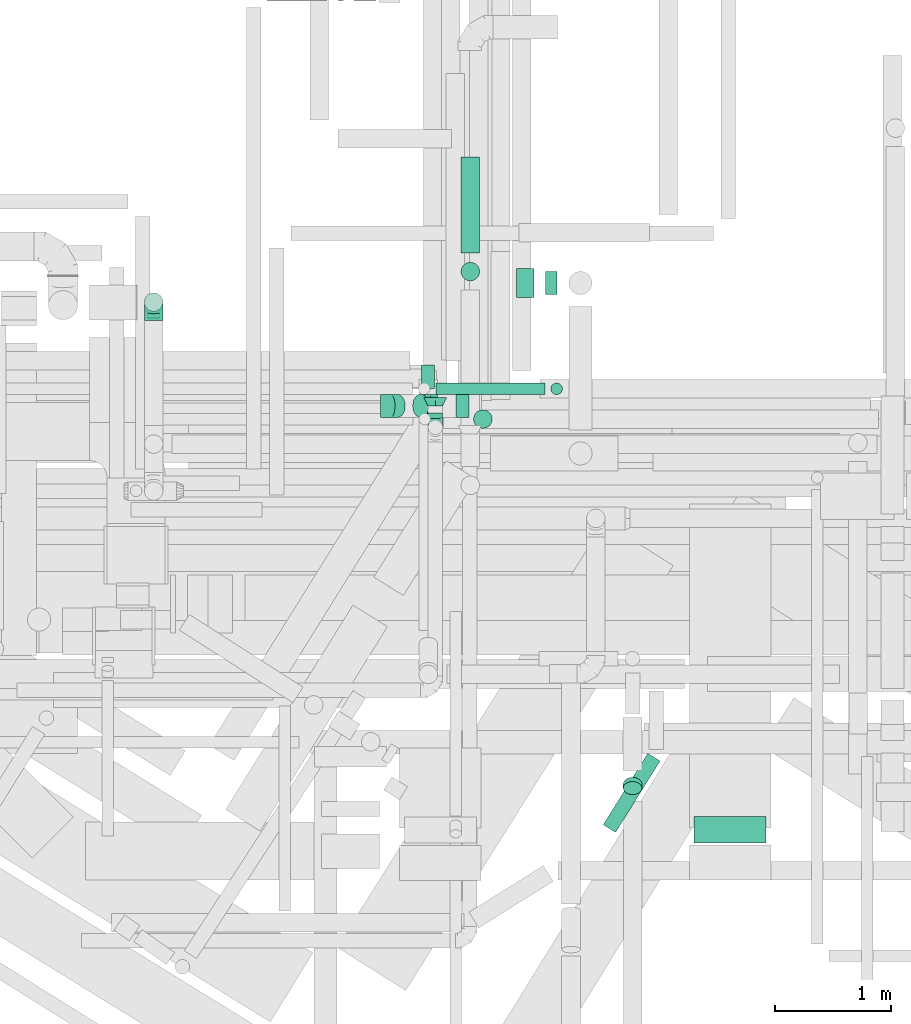
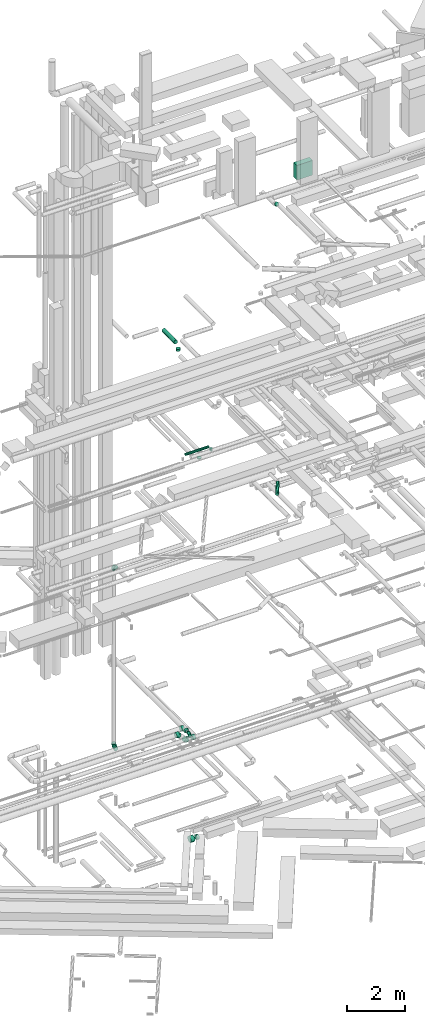
# One storey, part 101 of 337: 10 flow segments, 8 flow fittings.
"""IFC2X3 building model written with IfcOpenShell, lengths in millimetres."""

from ifc_helpers import new_model, entity, si_unit, converted_unit, derived_unit, direction, frame, origin, origin_2d_with_axis, place, context, subcontext, project, spatial, rectangle, circle, extrude, faceted_brep, source, transform, mapped, material, type_object, type_shapes, element, save


model = new_model("IFC2X3")

# Units and contexts
model_context = context("Model", 3, precision=0.01, world=origin(), true_north=direction((6.12303176911189e-17, 1.0)))
body_context = subcontext(model_context, "Body", "Model", "MODEL_VIEW")
ifc_project = project(units=[si_unit("LENGTHUNIT", "METRE", prefix="MILLI"), si_unit("AREAUNIT", "SQUARE_METRE"), si_unit("VOLUMEUNIT", "CUBIC_METRE"), converted_unit("PLANEANGLEUNIT", "DEGREE", entity("IfcRatioMeasure", 0.0174532925199433), si_unit("PLANEANGLEUNIT", "RADIAN"), dimensions=[0, 0, 0, 0, 0, 0, 0]), si_unit("MASSUNIT", "GRAM", prefix="KILO"), derived_unit("MASSDENSITYUNIT", [(si_unit("MASSUNIT", "GRAM", prefix="KILO"), 1), (si_unit("LENGTHUNIT", "METRE"), -3)]), derived_unit("MOMENTOFINERTIAUNIT", [(si_unit("LENGTHUNIT", "METRE"), 4)]), si_unit("TIMEUNIT", "SECOND"), si_unit("FREQUENCYUNIT", "HERTZ"), si_unit("THERMODYNAMICTEMPERATUREUNIT", "DEGREE_CELSIUS"), derived_unit("THERMALTRANSMITTANCEUNIT", [(si_unit("MASSUNIT", "GRAM", prefix="KILO"), 1), (si_unit("THERMODYNAMICTEMPERATUREUNIT", "KELVIN"), -1), (si_unit("TIMEUNIT", "SECOND"), -3)]), derived_unit("VOLUMETRICFLOWRATEUNIT", [(si_unit("LENGTHUNIT", "METRE"), 3), (si_unit("TIMEUNIT", "SECOND"), -1)]), derived_unit("MASSFLOWRATEUNIT", [(si_unit("MASSUNIT", "GRAM", prefix="KILO"), 1), (si_unit("TIMEUNIT", "SECOND"), -1)]), derived_unit("ROTATIONALFREQUENCYUNIT", [(si_unit("TIMEUNIT", "SECOND"), -1)]), si_unit("ELECTRICCURRENTUNIT", "AMPERE"), si_unit("ELECTRICVOLTAGEUNIT", "VOLT"), si_unit("POWERUNIT", "WATT"), si_unit("FORCEUNIT", "NEWTON", prefix="KILO"), si_unit("ILLUMINANCEUNIT", "LUX"), si_unit("LUMINOUSFLUXUNIT", "LUMEN"), si_unit("LUMINOUSINTENSITYUNIT", "CANDELA"), derived_unit("USERDEFINED", [(si_unit("MASSUNIT", "GRAM", prefix="KILO"), -1), (si_unit("LENGTHUNIT", "METRE"), -2), (si_unit("TIMEUNIT", "SECOND"), 3), (si_unit("LUMINOUSFLUXUNIT", "LUMEN"), 1)]), derived_unit("LINEARVELOCITYUNIT", [(si_unit("LENGTHUNIT", "METRE"), 1), (si_unit("TIMEUNIT", "SECOND"), -1)]), si_unit("PRESSUREUNIT", "PASCAL"), derived_unit("USERDEFINED", [(si_unit("LENGTHUNIT", "METRE"), -2), (si_unit("MASSUNIT", "GRAM", prefix="KILO"), 1), (si_unit("TIMEUNIT", "SECOND"), -2)]), derived_unit("LINEARFORCEUNIT", [(si_unit("MASSUNIT", "GRAM", prefix="KILO"), 1), (si_unit("LENGTHUNIT", "METRE"), 1), (si_unit("TIMEUNIT", "SECOND"), -2), (si_unit("LENGTHUNIT", "METRE"), -1)]), derived_unit("PLANARFORCEUNIT", [(si_unit("MASSUNIT", "GRAM", prefix="KILO"), 1), (si_unit("LENGTHUNIT", "METRE"), 1), (si_unit("TIMEUNIT", "SECOND"), -2), (si_unit("LENGTHUNIT", "METRE"), -2)])], contexts=[model_context])

# Site, building, storey
site_placement = place(None, origin())
site = spatial("IfcSite", under=ifc_project, at=site_placement, CompositionType="ELEMENT")
building_placement = place(site_placement, origin())
building = spatial("IfcBuilding", under=site, at=building_placement, CompositionType="ELEMENT")
storey_placement = place(building_placement, origin())
storey = spatial("IfcBuildingStorey", under=building, at=storey_placement, CompositionType="ELEMENT", Elevation=0.0)

# Flow segments
duct_segment_type_1 = type_object("IfcDuctSegmentType", PredefinedType="NOTDEFINED")
flow_segment_1_placement = place(storey_placement, frame((15177.92, 9281.6, 28512.0)))
element("IfcFlowSegment", 1, at=flow_segment_1_placement, inside=storey, type_object=duct_segment_type_1, context=body_context, shape_type="SweptSolid", body=[
    extrude(rectangle(XDim=228.096941669532, YDim=620.0, at=origin_2d_with_axis()), frame((310.0, 114.05, 0.0), z_axis=(0.0, 0.0, 1.0), x_axis=(0.0, -1.0, 0.0)), (0.0, 0.0, 1.0), 619.999999999998),
])
duct_segment_type_2 = type_object("IfcDuctSegmentType", PredefinedType="NOTDEFINED")
flow_segment_2_placement = place(storey_placement, frame((13648.94, 13974.38, -1929.6)))
element("IfcFlowSegment", 2, at=flow_segment_2_placement, inside=storey, type_object=duct_segment_type_2, context=body_context, shape_type="SweptSolid", body=[
    extrude(circle(Radius=125.0, at=origin_2d_with_axis()), frame((0.0, 126.6, 126.6), z_axis=(1.0, 0.0, 0.0), x_axis=(0.0, 1.0, 0.0)), (0.0, 0.0, 1.0), 151.417781054954),
])
flow_segment_3_placement = place(storey_placement, frame((13900.36, 13999.38, -1904.6)))
element("IfcFlowSegment", 3, at=flow_segment_3_placement, inside=storey, type_object=duct_segment_type_2, context=body_context, shape_type="SweptSolid", body=[
    extrude(circle(Radius=100.0, at=origin_2d_with_axis()), frame((0.0, 101.6, 101.6), z_axis=(1.0, 0.0, 0.0), x_axis=(0.0, 1.0, 0.0)), (0.0, 0.0, 1.0), 98.636704749991),
])
flow_segment_4_placement = place(storey_placement, frame((14394.03, 9370.13, 15323.4)))
element("IfcFlowSegment", 4, at=flow_segment_4_placement, inside=storey, type_object=duct_segment_type_2, context=body_context, shape_type="SweptSolid", body=[
    extrude(circle(Radius=62.5, at=origin_2d_with_axis()), frame((54.64, 34.65, 64.1), z_axis=(0.528869419396582, 0.848703209153307, 0.0), x_axis=(-0.848703209153307, 0.528869419396582, 0.0)), (0.0, 0.0, 1.0), 724.259417850464),
])
flow_segment_5_placement = place(storey_placement, frame((12953.67, 13138.4, 15248.4)))
element("IfcFlowSegment", 5, at=flow_segment_5_placement, inside=storey, type_object=duct_segment_type_2, context=body_context, shape_type="SweptSolid", body=[
    extrude(circle(Radius=50.0, at=origin_2d_with_axis()), frame((0.0, 51.6, 51.6), z_axis=(1.0, 0.0, 0.0), x_axis=(0.0, 1.0, 0.0)), (0.0, 0.0, 1.0), 940.000000000031),
])
flow_segment_6_placement = place(storey_placement, frame((13942.08, 13138.4, 15100.0)))
element("IfcFlowSegment", 6, at=flow_segment_6_placement, inside=storey, type_object=duct_segment_type_2, context=body_context, shape_type="SweptSolid", body=[
    extrude(circle(Radius=50.0, at=origin_2d_with_axis()), frame((51.6, 51.6, 0.0), z_axis=(0.0, 0.0, 1.0), x_axis=(0.0, 1.0, 0.0)), (0.0, 0.0, 1.0), 99.9999999999946),
])
flow_segment_7_placement = place(storey_placement, frame((13169.37, 14359.81, 19168.4)))
element("IfcFlowSegment", 7, at=flow_segment_7_placement, inside=storey, type_object=duct_segment_type_2, context=body_context, shape_type="SweptSolid", body=[
    extrude(circle(Radius=80.0, at=origin_2d_with_axis()), frame((81.6, 0.0, 81.6), z_axis=(0.0, 1.0, 0.0), x_axis=(-1.0, 0.0, 0.0)), (0.0, 0.0, 1.0), 825.000000000012),
])
flow_segment_8_placement = place(storey_placement, frame((13169.37, 14118.22, 18995.0)))
element("IfcFlowSegment", 8, at=flow_segment_8_placement, inside=storey, type_object=duct_segment_type_2, context=body_context, shape_type="SweptSolid", body=[
    extrude(circle(Radius=80.0, at=origin_2d_with_axis()), frame((81.6, 81.6, 0.0), z_axis=(0.0, 0.0, 1.0), x_axis=(-1.0, 0.0, 0.0)), (0.0, 0.0, 1.0), 94.9999999999892),
])
flow_segment_9_placement = place(storey_placement, frame((13277.81, 12848.4, 15160.0)))
element("IfcFlowSegment", 9, at=flow_segment_9_placement, inside=storey, type_object=duct_segment_type_2, context=body_context, shape_type="SweptSolid", body=[
    extrude(circle(Radius=80.0, at=origin_2d_with_axis()), frame((81.6, 81.6, 0.0), z_axis=(0.0, 0.0, 1.0), x_axis=(-1.0, 0.0, 0.0)), (0.0, 0.0, 1.0), 39.9999999999173),
])
flow_segment_10_placement = place(storey_placement, frame((14565.83, 9694.83, 27308.7)))
element("IfcFlowSegment", 10, at=flow_segment_10_placement, inside=storey, type_object=duct_segment_type_2, context=body_context, shape_type="SweptSolid", body=[
    extrude(circle(Radius=80.0, at=origin_2d_with_axis()), frame((81.6, 94.44, 58.16), z_axis=(0.0, -0.707106626710859, 0.707106935662202), x_axis=(-1.0, 0.0, 0.0)), (0.0, 0.0, 1.0), 51.2993420344718),
])

# Flow fittings
ifc_material = material()
duct_fitting_type_1 = type_object("IfcDuctFittingType", PredefinedType="NOTDEFINED", material=ifc_material)
shared_shape_1 = source(origin(), body_context, "Body", "Brep", [
    faceted_brep([(-160.0, 0.0, -80.0), (-160.0, -20.71, -77.27), (-160.0, -40.0, -69.28), (-160.0, -56.57, -56.57), (-160.0, -69.28, -40.0), (-160.0, -77.27, -20.71), (-160.0, -80.0, 0.0), (-160.0, -77.27, 20.71), (-160.0, -69.28, 40.0), (-160.0, -56.57, 56.57), (-160.0, -40.0, 69.28), (-160.0, -20.71, 77.27), (-160.0, 0.0, 80.0), (-160.0, 20.71, 77.27), (-160.0, 40.0, 69.28), (-160.0, 56.57, 56.57), (-160.0, 69.28, 40.0), (-160.0, 77.27, 20.71), (-160.0, 80.0, 0.0), (-160.0, 77.27, -20.71), (-160.0, 69.28, -40.0), (-160.0, 56.57, -56.57), (-160.0, 40.0, -69.28), (-160.0, 20.71, -77.27), (-122.68, 20.71, 77.27), (-127.85, 40.0, 69.28), (-117.13, 0.0, 80.0), (-132.29, 56.57, 56.57), (-137.83, 77.27, 20.71), (-138.56, 80.0, 0.0), (-135.69, 69.28, 40.0), (-135.69, 69.28, -40.0), (-132.29, 56.57, -56.57), (-137.83, 77.27, -20.71), (-122.68, 20.71, -77.27), (-117.13, 0.0, -80.0), (-127.85, 40.0, -69.28), (-111.58, -20.71, -77.27), (-106.41, -40.0, -69.28), (-101.97, -56.57, -56.57), (-98.56, -69.28, -40.0), (-96.42, -77.27, -20.71), (-95.69, -80.0, 0.0), (-96.42, -77.27, 20.71), (-98.56, -69.28, 40.0), (-101.97, -56.57, 56.57), (-106.41, -40.0, 69.28), (-111.58, -20.71, 77.27), (-58.03, 58.03, 77.27), (-72.15, 72.15, 69.28), (-42.87, 42.87, 80.0), (-84.28, 84.28, 56.57), (-93.59, 93.59, 40.0), (-99.44, 99.44, 20.71), (-101.44, 101.44, 0.0), (-99.44, 99.44, -20.71), (-93.59, 93.59, -40.0), (-84.28, 84.28, -56.57), (-58.03, 58.03, -77.27), (-42.87, 42.87, -80.0), (-72.15, 72.15, -69.28), (-27.71, 27.71, -77.27), (-13.59, 13.59, -69.28), (-1.46, 1.46, -56.57), (7.85, -7.85, -40.0), (13.7, -13.7, -20.71), (15.69, -15.69, 0.0), (13.7, -13.7, 20.71), (7.85, -7.85, 40.0), (-1.46, 1.46, 56.57), (-13.59, 13.59, 69.28), (-27.71, 27.71, 77.27), (-20.71, 122.68, 77.27), (-40.0, 127.85, 69.28), (0.0, 117.13, 80.0), (-56.57, 132.29, 56.57), (-69.28, 135.69, 40.0), (-77.27, 137.83, 20.71), (-80.0, 138.56, 0.0), (-77.27, 137.83, -20.71), (-69.28, 135.69, -40.0), (-56.57, 132.29, -56.57), (-20.71, 122.68, -77.27), (0.0, 117.13, -80.0), (-40.0, 127.85, -69.28), (20.71, 111.58, -77.27), (40.0, 106.41, -69.28), (56.57, 101.97, -56.57), (69.28, 98.56, -40.0), (77.27, 96.42, -20.71), (80.0, 95.69, 0.0), (77.27, 96.42, 20.71), (69.28, 98.56, 40.0), (56.57, 101.97, 56.57), (40.0, 106.41, 69.28), (20.71, 111.58, 77.27), (-20.71, 160.0, -77.27), (-40.0, 160.0, -69.28), (-56.57, 160.0, -56.57), (-69.28, 160.0, -40.0), (-77.27, 160.0, -20.71), (-80.0, 160.0, 0.0), (-77.27, 160.0, 20.71), (-69.28, 160.0, 40.0), (-56.57, 160.0, 56.57), (-40.0, 160.0, 69.28), (-20.71, 160.0, 77.27), (0.0, 160.0, 80.0), (20.71, 160.0, 77.27), (40.0, 160.0, 69.28), (56.57, 160.0, 56.57), (69.28, 160.0, 40.0), (77.27, 160.0, 20.71), (80.0, 160.0, 0.0), (77.27, 160.0, -20.71), (69.28, 160.0, -40.0), (56.57, 160.0, -56.57), (40.0, 160.0, -69.28), (20.71, 160.0, -77.27), (0.0, 160.0, -80.0)], [[[0, 1, 2, 3, 4, 5, 6, 7, 8, 9, 10, 11, 12, 13, 14, 15, 16, 17, 18, 19, 20, 21, 22, 23]], [[24, 25, 14, 13]], [[26, 24, 13, 12]], [[14, 25, 27, 15]], [[28, 29, 18, 17]], [[30, 28, 17, 16]], [[15, 27, 30, 16]], [[20, 31, 32, 21]], [[33, 31, 20, 19]], [[18, 29, 33, 19]], [[34, 35, 0, 23]], [[36, 34, 23, 22]], [[32, 36, 22, 21]], [[1, 0, 35, 37]], [[2, 1, 37, 38]], [[3, 2, 38, 39]], [[5, 4, 40, 41]], [[6, 5, 41, 42]], [[39, 40, 4, 3]], [[6, 42, 43, 7]], [[7, 43, 44, 8]], [[8, 44, 45, 9]], [[9, 45, 46, 10]], [[10, 46, 47, 11]], [[26, 12, 11, 47]], [[48, 49, 25, 24]], [[50, 48, 24, 26]], [[27, 25, 49, 51]], [[52, 53, 28, 30]], [[51, 52, 30, 27]], [[29, 28, 53, 54]], [[55, 56, 31, 33]], [[54, 55, 33, 29]], [[32, 31, 56, 57]], [[58, 59, 35, 34]], [[60, 58, 34, 36]], [[57, 60, 36, 32]], [[37, 35, 59, 61]], [[38, 37, 61, 62]], [[39, 38, 62, 63]], [[41, 40, 64, 65]], [[42, 41, 65, 66]], [[63, 64, 40, 39]], [[43, 42, 66, 67]], [[44, 43, 67, 68]], [[68, 69, 45, 44]], [[46, 45, 69, 70]], [[47, 46, 70, 71]], [[26, 47, 71, 50]], [[72, 73, 49, 48]], [[74, 72, 48, 50]], [[51, 49, 73, 75]], [[76, 77, 53, 52]], [[75, 76, 52, 51]], [[54, 53, 77, 78]], [[79, 80, 56, 55]], [[78, 79, 55, 54]], [[57, 56, 80, 81]], [[82, 83, 59, 58]], [[84, 82, 58, 60]], [[81, 84, 60, 57]], [[61, 59, 83, 85]], [[62, 61, 85, 86]], [[63, 62, 86, 87]], [[65, 64, 88, 89]], [[66, 65, 89, 90]], [[87, 88, 64, 63]], [[67, 66, 90, 91]], [[68, 67, 91, 92]], [[92, 93, 69, 68]], [[70, 69, 93, 94]], [[71, 70, 94, 95]], [[50, 71, 95, 74]], [[96, 97, 98, 99, 100, 101, 102, 103, 104, 105, 106, 107, 108, 109, 110, 111, 112, 113, 114, 115, 116, 117, 118, 119]], [[72, 74, 107, 106]], [[73, 72, 106, 105]], [[75, 73, 105, 104]], [[77, 76, 103, 102]], [[78, 77, 102, 101]], [[75, 104, 103, 76]], [[78, 101, 100, 79]], [[79, 100, 99, 80]], [[80, 99, 98, 81]], [[84, 97, 96, 82]], [[82, 96, 119, 83]], [[84, 81, 98, 97]], [[118, 117, 86, 85]], [[119, 118, 85, 83]], [[116, 87, 86, 117]], [[88, 115, 114, 89]], [[89, 114, 113, 90]], [[115, 88, 87, 116]], [[112, 111, 92, 91]], [[113, 112, 91, 90]], [[111, 110, 93, 92]], [[95, 94, 109, 108]], [[74, 95, 108, 107]], [[110, 109, 94, 93]]]),
])
type_shapes(duct_fitting_type_1, [shared_shape_1])
for number, where, z_axis, x_axis in (
    (11, (10524.9, 13936.5, 3320.0), (1.0, 0.0, 0.0), (0.0, 1.0, 0.0)),
    (12, (10524.9, 13936.5, 11000.0), (-1.0, 0.0, 0.0), (0.0, 1.0, 0.0)),
):
    element("IfcFlowFitting", number, at=place(storey_placement, frame(where, z_axis=z_axis, x_axis=x_axis)), inside=storey, type_object=duct_fitting_type_1, material=ifc_material, context=body_context, shape_type="MappedRepresentation", body=[
        mapped(shared_shape_1, transform((0.0, 0.0, 0.0), scale=1.0)),
    ])
duct_fitting_type_2 = type_object("IfcDuctFittingType", PredefinedType="NOTDEFINED", material=ifc_material)
shared_shape_2 = source(origin(), body_context, "Body", "Brep", [
    faceted_brep([(-125.0, 0.0, -62.5), (-125.0, -16.18, -60.37), (-125.0, -31.25, -54.13), (-125.0, -44.19, -44.19), (-125.0, -54.13, -31.25), (-125.0, -60.37, -16.18), (-125.0, -62.5, 0.0), (-125.0, -60.37, 16.18), (-125.0, -54.13, 31.25), (-125.0, -44.19, 44.19), (-125.0, -31.25, 54.13), (-125.0, -16.18, 60.37), (-125.0, 0.0, 62.5), (-125.0, 16.18, 60.37), (-125.0, 31.25, 54.13), (-125.0, 44.19, 44.19), (-125.0, 54.13, 31.25), (-125.0, 60.37, 16.18), (-125.0, 62.5, 0.0), (-125.0, 60.37, -16.18), (-125.0, 54.13, -31.25), (-125.0, 44.19, -44.19), (-125.0, 31.25, -54.13), (-125.0, 16.18, -60.37), (-95.84, 16.18, 60.37), (-99.88, 31.25, 54.13), (-91.51, 0.0, 62.5), (-103.35, 44.19, 44.19), (-107.68, 60.37, 16.18), (-108.25, 62.5, 0.0), (-106.01, 54.13, 31.25), (-106.01, 54.13, -31.25), (-103.35, 44.19, -44.19), (-107.68, 60.37, -16.18), (-95.84, 16.18, -60.37), (-91.51, 0.0, -62.5), (-99.88, 31.25, -54.13), (-87.17, -16.18, -60.37), (-83.13, -31.25, -54.13), (-79.66, -44.19, -44.19), (-77.0, -54.13, -31.25), (-75.33, -60.37, -16.18), (-74.76, -62.5, 0.0), (-75.33, -60.37, 16.18), (-77.0, -54.13, 31.25), (-79.66, -44.19, 44.19), (-83.13, -31.25, 54.13), (-87.17, -16.18, 60.37), (-45.34, 45.34, 60.37), (-56.37, 56.37, 54.13), (-33.49, 33.49, 62.5), (-65.85, 65.85, 44.19), (-73.12, 73.12, 31.25), (-77.69, 77.69, 16.18), (-79.25, 79.25, 0.0), (-77.69, 77.69, -16.18), (-73.12, 73.12, -31.25), (-65.85, 65.85, -44.19), (-45.34, 45.34, -60.37), (-33.49, 33.49, -62.5), (-56.37, 56.37, -54.13), (-21.65, 21.65, -60.37), (-10.62, 10.62, -54.13), (-1.14, 1.14, -44.19), (6.13, -6.13, -31.25), (10.7, -10.7, -16.18), (12.26, -12.26, 0.0), (10.7, -10.7, 16.18), (6.13, -6.13, 31.25), (-1.14, 1.14, 44.19), (-10.62, 10.62, 54.13), (-21.65, 21.65, 60.37), (-16.18, 95.84, 60.37), (-31.25, 99.88, 54.13), (0.0, 91.51, 62.5), (-44.19, 103.35, 44.19), (-54.13, 106.01, 31.25), (-60.37, 107.68, 16.18), (-62.5, 108.25, 0.0), (-60.37, 107.68, -16.18), (-54.13, 106.01, -31.25), (-44.19, 103.35, -44.19), (-16.18, 95.84, -60.37), (0.0, 91.51, -62.5), (-31.25, 99.88, -54.13), (16.18, 87.17, -60.37), (31.25, 83.13, -54.13), (44.19, 79.66, -44.19), (54.13, 77.0, -31.25), (60.37, 75.33, -16.18), (62.5, 74.76, 0.0), (60.37, 75.33, 16.18), (54.13, 77.0, 31.25), (44.19, 79.66, 44.19), (31.25, 83.13, 54.13), (16.18, 87.17, 60.37), (-16.18, 125.0, -60.37), (-31.25, 125.0, -54.13), (-44.19, 125.0, -44.19), (-54.13, 125.0, -31.25), (-60.37, 125.0, -16.18), (-62.5, 125.0, 0.0), (-60.37, 125.0, 16.18), (-54.13, 125.0, 31.25), (-44.19, 125.0, 44.19), (-31.25, 125.0, 54.13), (-16.18, 125.0, 60.37), (0.0, 125.0, 62.5), (16.18, 125.0, 60.37), (31.25, 125.0, 54.13), (44.19, 125.0, 44.19), (54.13, 125.0, 31.25), (60.37, 125.0, 16.18), (62.5, 125.0, 0.0), (60.37, 125.0, -16.18), (54.13, 125.0, -31.25), (44.19, 125.0, -44.19), (31.25, 125.0, -54.13), (16.18, 125.0, -60.37), (0.0, 125.0, -62.5)], [[[0, 1, 2, 3, 4, 5, 6, 7, 8, 9, 10, 11, 12, 13, 14, 15, 16, 17, 18, 19, 20, 21, 22, 23]], [[24, 25, 14, 13]], [[26, 24, 13, 12]], [[14, 25, 27, 15]], [[28, 29, 18, 17]], [[30, 28, 17, 16]], [[15, 27, 30, 16]], [[20, 31, 32, 21]], [[33, 31, 20, 19]], [[18, 29, 33, 19]], [[34, 35, 0, 23]], [[36, 34, 23, 22]], [[21, 32, 36, 22]], [[1, 0, 35, 37]], [[2, 1, 37, 38]], [[38, 39, 3, 2]], [[5, 4, 40, 41]], [[6, 5, 41, 42]], [[39, 40, 4, 3]], [[6, 42, 43, 7]], [[7, 43, 44, 8]], [[45, 9, 8, 44]], [[9, 45, 46, 10]], [[10, 46, 47, 11]], [[26, 12, 11, 47]], [[48, 49, 25, 24]], [[50, 48, 24, 26]], [[27, 25, 49, 51]], [[52, 53, 28, 30]], [[51, 52, 30, 27]], [[29, 28, 53, 54]], [[55, 56, 31, 33]], [[54, 55, 33, 29]], [[57, 32, 31, 56]], [[58, 59, 35, 34]], [[60, 58, 34, 36]], [[57, 60, 36, 32]], [[37, 35, 59, 61]], [[38, 37, 61, 62]], [[39, 38, 62, 63]], [[41, 40, 64, 65]], [[42, 41, 65, 66]], [[63, 64, 40, 39]], [[43, 42, 66, 67]], [[44, 43, 67, 68]], [[68, 69, 45, 44]], [[46, 45, 69, 70]], [[47, 46, 70, 71]], [[26, 47, 71, 50]], [[72, 73, 49, 48]], [[74, 72, 48, 50]], [[51, 49, 73, 75]], [[76, 77, 53, 52]], [[75, 76, 52, 51]], [[54, 53, 77, 78]], [[79, 80, 56, 55]], [[78, 79, 55, 54]], [[81, 57, 56, 80]], [[82, 83, 59, 58]], [[84, 82, 58, 60]], [[81, 84, 60, 57]], [[61, 59, 83, 85]], [[62, 61, 85, 86]], [[63, 62, 86, 87]], [[65, 64, 88, 89]], [[66, 65, 89, 90]], [[87, 88, 64, 63]], [[67, 66, 90, 91]], [[68, 67, 91, 92]], [[92, 93, 69, 68]], [[70, 69, 93, 94]], [[71, 70, 94, 95]], [[50, 71, 95, 74]], [[96, 97, 98, 99, 100, 101, 102, 103, 104, 105, 106, 107, 108, 109, 110, 111, 112, 113, 114, 115, 116, 117, 118, 119]], [[72, 74, 107, 106]], [[73, 72, 106, 105]], [[75, 73, 105, 104]], [[77, 76, 103, 102]], [[78, 77, 102, 101]], [[75, 104, 103, 76]], [[78, 101, 100, 79]], [[79, 100, 99, 80]], [[80, 99, 98, 81]], [[96, 119, 83, 82]], [[97, 96, 82, 84]], [[84, 81, 98, 97]], [[83, 119, 118, 85]], [[85, 118, 117, 86]], [[116, 87, 86, 117]], [[88, 115, 114, 89]], [[89, 114, 113, 90]], [[115, 88, 87, 116]], [[91, 90, 113, 112]], [[92, 91, 112, 111]], [[111, 110, 93, 92]], [[95, 94, 109, 108]], [[74, 95, 108, 107]], [[110, 109, 94, 93]]]),
])
type_shapes(duct_fitting_type_2, [shared_shape_2])
flow_fitting_1_placement = place(storey_placement, frame((12949.17, 12858.38, 3660.0), z_axis=(1.0, 0.0, 0.0), x_axis=(0.0, -1.0, 0.0)))
element("IfcFlowFitting", 13, at=flow_fitting_1_placement, inside=storey, type_object=duct_fitting_type_2, material=ifc_material, context=body_context, shape_type="MappedRepresentation", body=[
    mapped(shared_shape_2, transform((0.0, 0.0, 0.0), scale=1.0)),
])
duct_fitting_type_3 = type_object("IfcDuctFittingType", PredefinedType="NOTDEFINED", material=ifc_material)
shared_shape_3 = source(origin(), body_context, "Body", "Brep", [
    faceted_brep([(75.0, -57.74, 23.92), (75.0, -60.12, 11.96), (75.0, -62.5, 0.0), (75.0, -60.12, -11.96), (75.0, -57.74, -23.92), (75.0, -50.97, -34.06), (75.0, -44.19, -44.19), (75.0, -34.06, -50.97), (75.0, -23.92, -57.74), (75.0, -11.96, -60.12), (75.0, 0.0, -62.5), (75.0, 11.96, -60.12), (75.0, 23.92, -57.74), (75.0, 34.06, -50.97), (75.0, 44.19, -44.19), (75.0, 50.97, -34.06), (75.0, 57.74, -23.92), (75.0, 60.12, -11.96), (75.0, 62.5, 0.0), (75.0, 60.12, 11.96), (75.0, 57.74, 23.92), (75.0, 50.97, 34.06), (75.0, 44.19, 44.19), (75.0, 34.06, 50.97), (75.0, 23.92, 57.74), (75.0, 11.96, 60.12), (75.0, 0.0, 62.5), (75.0, -11.96, 60.12), (75.0, -23.92, 57.74), (75.0, -34.06, 50.97), (75.0, -44.19, 44.19), (75.0, -50.97, 34.06), (0.0, -100.0, 0.0), (0.0, -95.11, 30.9), (0.0, -80.9, 58.78), (0.0, -58.78, 80.9), (0.0, -30.9, 95.11), (0.0, 0.0, 100.0), (0.0, 30.9, 95.11), (0.0, 58.78, 80.9), (0.0, 80.9, 58.78), (0.0, 95.11, 30.9), (0.0, 100.0, 0.0), (0.0, 95.11, -30.9), (0.0, 80.9, -58.78), (0.0, 58.78, -80.9), (0.0, 30.9, -95.11), (0.0, 0.0, -100.0), (0.0, -30.9, -95.11), (0.0, -58.78, -80.9), (0.0, -80.9, -58.78), (0.0, -95.11, -30.9)], [[[0, 1, 2, 3, 4, 5, 6, 7, 8, 9, 10, 11, 12, 13, 14, 15, 16, 17, 18, 19, 20, 21, 22, 23, 24, 25, 26, 27, 28, 29, 30, 31]], [[32, 33, 34, 35, 36, 37, 38, 39, 40, 41, 42, 43, 44, 45, 46, 47, 48, 49, 50, 51]], [[37, 25, 38]], [[41, 20, 19]], [[24, 39, 38]], [[40, 22, 21, 20]], [[23, 22, 39, 24]], [[18, 42, 19]], [[25, 24, 38]], [[40, 20, 41]], [[19, 42, 41]], [[25, 37, 26]], [[22, 40, 39]], [[32, 1, 33]], [[36, 28, 27]], [[0, 34, 33]], [[35, 30, 29, 28]], [[31, 30, 34, 0]], [[26, 37, 27]], [[1, 0, 33]], [[35, 28, 36]], [[27, 37, 36]], [[1, 32, 2]], [[30, 35, 34]], [[47, 9, 48]], [[51, 4, 3]], [[8, 49, 48]], [[50, 6, 5, 4]], [[7, 6, 49, 8]], [[2, 32, 3]], [[9, 8, 48]], [[50, 4, 51]], [[3, 32, 51]], [[9, 47, 10]], [[6, 50, 49]], [[42, 17, 43]], [[46, 12, 11]], [[16, 44, 43]], [[45, 14, 13, 12]], [[15, 14, 44, 16]], [[10, 47, 11]], [[17, 16, 43]], [[45, 12, 46]], [[11, 47, 46]], [[17, 42, 18]], [[14, 45, 44]]]),
])
type_shapes(duct_fitting_type_3, [shared_shape_3])
flow_fitting_2_placement = place(storey_placement, frame((12949.17, 13115.88, 3660.0), z_axis=(0.0, 0.0, 1.0), x_axis=(0.0, -1.0, 0.0)))
element("IfcFlowFitting", 14, at=flow_fitting_2_placement, inside=storey, type_object=duct_fitting_type_3, material=ifc_material, context=body_context, shape_type="MappedRepresentation", body=[
    mapped(shared_shape_3, transform((0.0, 0.0, 0.0), scale=1.0)),
])
duct_fitting_type_4 = type_object("IfcDuctFittingType", PredefinedType="NOTDEFINED", material=ifc_material)
shared_shape_4 = source(origin(), body_context, "Body", "Brep", [
    faceted_brep([(-82.84, 0.0, -100.0), (-82.84, -25.88, -96.59), (-82.84, -50.0, -86.6), (-82.84, -70.71, -70.71), (-82.84, -86.6, -50.0), (-82.84, -96.59, -25.88), (-82.84, -100.0, 0.0), (-82.84, -96.59, 25.88), (-82.84, -86.6, 50.0), (-82.84, -70.71, 70.71), (-82.84, -50.0, 86.6), (-82.84, -25.88, 96.59), (-82.84, 0.0, 100.0), (-82.84, 25.88, 96.59), (-82.84, 50.0, 86.6), (-82.84, 70.71, 70.71), (-82.84, 86.6, 50.0), (-82.84, 96.59, 25.88), (-82.84, 100.0, 0.0), (-82.84, 96.59, -25.88), (-82.84, 86.6, -50.0), (-82.84, 70.71, -70.71), (-82.84, 50.0, -86.6), (-82.84, 25.88, -96.59), (-10.72, 25.88, 96.59), (-20.71, 50.0, 86.6), (0.0, 0.0, 100.0), (-29.29, 70.71, 70.71), (-35.87, 86.6, 50.0), (-40.01, 96.59, 25.88), (-41.42, 100.0, 0.0), (-40.01, 96.59, -25.88), (-35.87, 86.6, -50.0), (-29.29, 70.71, -70.71), (-10.72, 25.88, -96.59), (0.0, 0.0, -100.0), (-20.71, 50.0, -86.6), (10.72, -25.88, -96.59), (20.71, -50.0, -86.6), (29.29, -70.71, -70.71), (35.87, -86.6, -50.0), (40.01, -96.59, -25.88), (41.42, -100.0, 0.0), (40.01, -96.59, 25.88), (35.87, -86.6, 50.0), (29.29, -70.71, 70.71), (20.71, -50.0, 86.6), (10.72, -25.88, 96.59), (58.58, 58.58, 100.0), (40.28, 76.88, 96.59), (23.22, 93.93, 86.6), (8.58, 108.58, 70.71), (-2.66, 119.82, 50.0), (-9.72, 126.88, 25.88), (-12.13, 129.29, 0.0), (-9.72, 126.88, -25.88), (-2.66, 119.82, -50.0), (8.58, 108.58, -70.71), (23.22, 93.93, -86.6), (40.28, 76.88, -96.59), (58.58, 58.58, -100.0), (76.88, 40.28, -96.59), (93.93, 23.22, -86.6), (108.58, 8.58, -70.71), (119.82, -2.66, -50.0), (126.88, -9.72, -25.88), (129.29, -12.13, 0.0), (126.88, -9.72, 25.88), (119.82, -2.66, 50.0), (108.58, 8.58, 70.71), (93.93, 23.22, 86.6), (76.88, 40.28, 96.59)], [[[0, 1, 2, 3, 4, 5, 6, 7, 8, 9, 10, 11, 12, 13, 14, 15, 16, 17, 18, 19, 20, 21, 22, 23]], [[24, 25, 14, 13]], [[26, 24, 13, 12]], [[14, 25, 27, 15]], [[28, 29, 17, 16]], [[28, 16, 15, 27]], [[30, 18, 17, 29]], [[31, 32, 20, 19]], [[30, 31, 19, 18]], [[32, 33, 21, 20]], [[34, 35, 0, 23]], [[36, 34, 23, 22]], [[33, 36, 22, 21]], [[1, 0, 35, 37]], [[2, 1, 37, 38]], [[38, 39, 3, 2]], [[5, 4, 40, 41]], [[6, 5, 41, 42]], [[39, 40, 4, 3]], [[6, 42, 43, 7]], [[7, 43, 44, 8]], [[8, 44, 45, 9]], [[9, 45, 46, 10]], [[10, 46, 47, 11]], [[26, 12, 11, 47]], [[24, 26, 48, 49]], [[25, 24, 49, 50]], [[27, 25, 50, 51]], [[29, 28, 52, 53]], [[30, 29, 53, 54]], [[51, 52, 28, 27]], [[30, 54, 55, 31]], [[31, 55, 56, 32]], [[57, 33, 32, 56]], [[36, 58, 59, 34]], [[34, 59, 60, 35]], [[58, 36, 33, 57]], [[35, 60, 61, 37]], [[37, 61, 62, 38]], [[63, 39, 38, 62]], [[40, 64, 65, 41]], [[41, 65, 66, 42]], [[64, 40, 39, 63]], [[43, 42, 66, 67]], [[44, 43, 67, 68]], [[68, 69, 45, 44]], [[47, 46, 70, 71]], [[26, 47, 71, 48]], [[69, 70, 46, 45]], [[59, 58, 57, 56, 55, 54, 53, 52, 51, 50, 49, 48, 71, 70, 69, 68, 67, 66, 65, 64, 63, 62, 61, 60]]]),
])
type_shapes(duct_fitting_type_4, [shared_shape_4])
for number, where, z_axis, x_axis in (
    (15, (12561.63, 13043.34, 3660.0), (0.0, 1.0, 0.0), (1.0, 0.0, 0.0)),
    (16, (12884.13, 13043.34, 3337.5), (0.0, -1.0, 0.0), (0.707106781186515, 0.0, -0.70710678118658)),
):
    element("IfcFlowFitting", number, at=place(storey_placement, frame(where, z_axis=z_axis, x_axis=x_axis)), inside=storey, type_object=duct_fitting_type_4, material=ifc_material, context=body_context, shape_type="MappedRepresentation", body=[
        mapped(shared_shape_4, transform((0.0, 0.0, 0.0), scale=1.0)),
    ])
duct_fitting_type_5 = type_object("IfcDuctFittingType", PredefinedType="NOTDEFINED", material=ifc_material)
shared_shape_5 = source(origin(), body_context, "Body", "Brep", [
    faceted_brep([(20.0, 25.88, -96.59), (20.0, 50.0, -86.6), (20.0, 70.71, -70.71), (20.0, 86.6, -50.0), (20.0, 96.59, -25.88), (20.0, 100.0, 0.0), (20.0, 96.59, 25.88), (20.0, 86.6, 50.0), (20.0, 70.71, 70.71), (20.0, 50.0, 86.6), (20.0, 25.88, 96.59), (20.0, 0.0, 100.0), (20.0, -25.88, 96.59), (20.0, -50.0, 86.6), (20.0, -70.71, 70.71), (20.0, -86.6, 50.0), (20.0, -96.59, 25.88), (20.0, -100.0, 0.0), (20.0, -96.59, -25.88), (20.0, -86.6, -50.0), (20.0, -70.71, -70.71), (20.0, -50.0, -86.6), (20.0, -25.88, -96.59), (20.0, 0.0, -100.0), (0.0, 0.0, 100.0), (0.0, 25.88, 96.59), (-93.9, 25.88, 96.59), (-93.9, 0.0, 100.0), (0.0, 50.0, 86.6), (-93.9, 50.0, 86.6), (0.0, 70.71, 70.71), (-93.9, 70.71, 70.71), (0.0, 86.6, 50.0), (0.0, 96.59, 25.88), (-93.9, 96.59, 25.88), (-93.9, 86.6, 50.0), (0.0, 100.0, 0.0), (-93.9, 100.0, 0.0), (0.0, 96.59, -25.88), (-93.9, 96.59, -25.88), (0.0, 86.6, -50.0), (-93.9, 86.6, -50.0), (0.0, 70.71, -70.71), (-93.9, 70.71, -70.71), (0.0, 50.0, -86.6), (0.0, 25.88, -96.59), (-93.9, 25.88, -96.59), (-93.9, 50.0, -86.6), (0.0, 0.0, -100.0), (-93.9, 0.0, -100.0), (0.0, -25.88, -96.59), (-93.9, -25.88, -96.59), (0.0, -50.0, -86.6), (-93.9, -50.0, -86.6), (0.0, -70.71, -70.71), (-93.9, -70.71, -70.71), (0.0, -86.6, -50.0), (0.0, -96.59, -25.88), (-93.9, -96.59, -25.88), (-93.9, -86.6, -50.0), (0.0, -100.0, 0.0), (-93.9, -100.0, 0.0), (0.0, -96.59, 25.88), (-93.9, -96.59, 25.88), (0.0, -86.6, 50.0), (-93.9, -86.6, 50.0), (0.0, -70.71, 70.71), (-93.9, -70.71, 70.71), (0.0, -50.0, 86.6), (0.0, -25.88, 96.59), (-93.9, -25.88, 96.59), (-93.9, -50.0, 86.6)], [[[0, 1, 2, 3, 4, 5, 6, 7, 8, 9, 10, 11, 12, 13, 14, 15, 16, 17, 18, 19, 20, 21, 22, 23]], [[24, 11, 10, 25, 26, 27]], [[25, 10, 9, 28, 29, 26]], [[28, 9, 8, 30, 31, 29]], [[32, 7, 6, 33, 34, 35]], [[33, 6, 5, 36, 37, 34]], [[30, 8, 7, 32, 35, 31]], [[36, 5, 4, 38, 39, 37]], [[38, 4, 3, 40, 41, 39]], [[40, 3, 2, 42, 43, 41]], [[44, 1, 0, 45, 46, 47]], [[45, 0, 23, 48, 49, 46]], [[42, 2, 1, 44, 47, 43]], [[48, 23, 22, 50, 51, 49]], [[50, 22, 21, 52, 53, 51]], [[52, 21, 20, 54, 55, 53]], [[56, 19, 18, 57, 58, 59]], [[57, 18, 17, 60, 61, 58]], [[54, 20, 19, 56, 59, 55]], [[60, 17, 16, 62, 63, 61]], [[62, 16, 15, 64, 65, 63]], [[64, 15, 14, 66, 67, 65]], [[68, 13, 12, 69, 70, 71]], [[69, 12, 11, 24, 27, 70]], [[66, 14, 13, 68, 71, 67]], [[49, 51, 53, 55, 59, 58, 61, 63, 65, 67, 71, 70, 27, 26, 29, 31, 35, 34, 37, 39, 41, 43, 47, 46]]]),
])
type_shapes(duct_fitting_type_5, [shared_shape_5])
for number, where, z_axis, x_axis in (
    (17, (12849.17, 13293.38, 3660.0), (0.0, 0.0, -1.0), (-1.0, 0.0, 0.0)),
    (18, (13146.63, 13043.34, 3337.5), (0.0, 0.0, -1.0), (-1.0, 0.0, 0.0)),
):
    element("IfcFlowFitting", number, at=place(storey_placement, frame(where, z_axis=z_axis, x_axis=x_axis)), inside=storey, type_object=duct_fitting_type_5, material=ifc_material, context=body_context, shape_type="MappedRepresentation", body=[
        mapped(shared_shape_5, transform((0.0, 0.0, 0.0), scale=1.0)),
    ])

save(model, "model.ifc")
